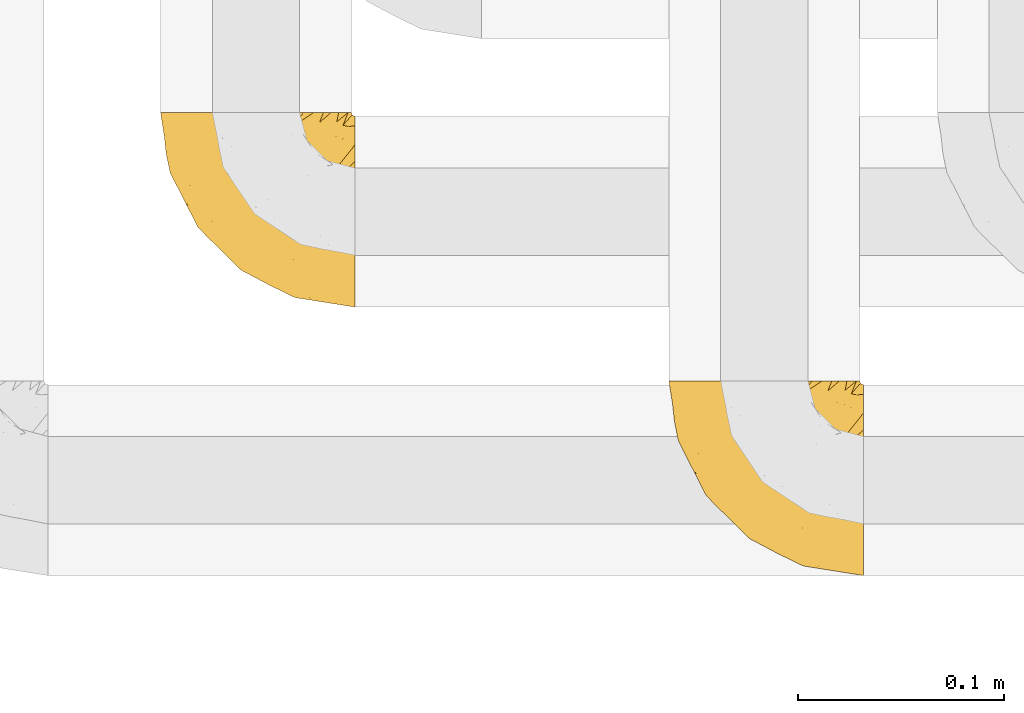
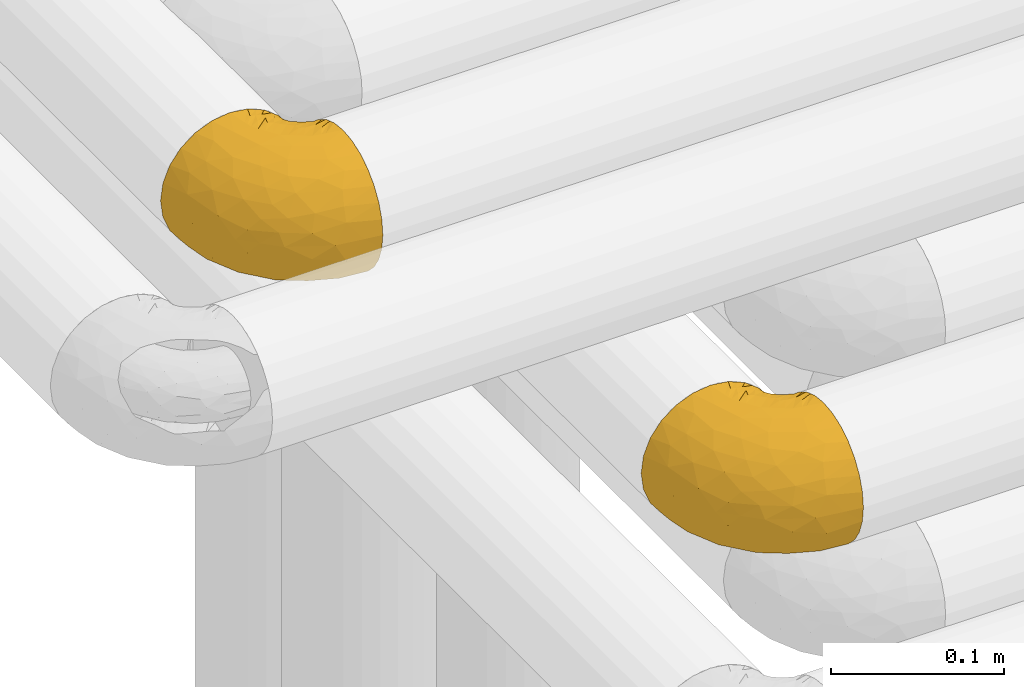
# One storey, part 143 of 827: 2 coverings.
"""IFC2X3 building model written with IfcOpenShell, lengths in millimetres."""

from ifc_helpers import new_model, entity, si_unit, converted_unit, derived_unit, direction, frame, origin, place, context, subcontext, project, spatial, faceted_brep, element, save


model = new_model("IFC2X3")

# Units and contexts
model_context = context("Model", 3, precision=0.01, world=origin(), true_north=direction((6.12303176911189e-17, 1.0)))
body_context = subcontext(model_context, "Body", "Model", "MODEL_VIEW")
ifc_project = project(units=[si_unit("LENGTHUNIT", "METRE", prefix="MILLI"), si_unit("AREAUNIT", "SQUARE_METRE"), si_unit("VOLUMEUNIT", "CUBIC_METRE"), converted_unit("PLANEANGLEUNIT", "DEGREE", entity("IfcRatioMeasure", 0.0174532925199433), si_unit("PLANEANGLEUNIT", "RADIAN"), dimensions=[0, 0, 0, 0, 0, 0, 0]), si_unit("MASSUNIT", "GRAM", prefix="KILO"), derived_unit("MASSDENSITYUNIT", [(si_unit("MASSUNIT", "GRAM", prefix="KILO"), 1), (si_unit("LENGTHUNIT", "METRE"), -3)]), derived_unit("MOMENTOFINERTIAUNIT", [(si_unit("LENGTHUNIT", "METRE"), 4)]), si_unit("TIMEUNIT", "SECOND"), si_unit("FREQUENCYUNIT", "HERTZ"), si_unit("THERMODYNAMICTEMPERATUREUNIT", "DEGREE_CELSIUS"), derived_unit("THERMALTRANSMITTANCEUNIT", [(si_unit("MASSUNIT", "GRAM", prefix="KILO"), 1), (si_unit("THERMODYNAMICTEMPERATUREUNIT", "KELVIN"), -1), (si_unit("TIMEUNIT", "SECOND"), -3)]), derived_unit("VOLUMETRICFLOWRATEUNIT", [(si_unit("LENGTHUNIT", "METRE"), 3), (si_unit("TIMEUNIT", "SECOND"), -1)]), derived_unit("MASSFLOWRATEUNIT", [(si_unit("MASSUNIT", "GRAM", prefix="KILO"), 1), (si_unit("TIMEUNIT", "SECOND"), -1)]), derived_unit("ROTATIONALFREQUENCYUNIT", [(si_unit("TIMEUNIT", "SECOND"), -1)]), si_unit("ELECTRICCURRENTUNIT", "AMPERE"), si_unit("ELECTRICVOLTAGEUNIT", "VOLT"), si_unit("POWERUNIT", "WATT"), si_unit("FORCEUNIT", "NEWTON", prefix="KILO"), si_unit("ILLUMINANCEUNIT", "LUX"), si_unit("LUMINOUSFLUXUNIT", "LUMEN"), si_unit("LUMINOUSINTENSITYUNIT", "CANDELA"), derived_unit("USERDEFINED", [(si_unit("MASSUNIT", "GRAM", prefix="KILO"), -1), (si_unit("LENGTHUNIT", "METRE"), -2), (si_unit("TIMEUNIT", "SECOND"), 3), (si_unit("LUMINOUSFLUXUNIT", "LUMEN"), 1)]), derived_unit("LINEARVELOCITYUNIT", [(si_unit("LENGTHUNIT", "METRE"), 1), (si_unit("TIMEUNIT", "SECOND"), -1)]), si_unit("PRESSUREUNIT", "PASCAL"), derived_unit("USERDEFINED", [(si_unit("LENGTHUNIT", "METRE"), -2), (si_unit("MASSUNIT", "GRAM", prefix="KILO"), 1), (si_unit("TIMEUNIT", "SECOND"), -2)]), derived_unit("LINEARFORCEUNIT", [(si_unit("MASSUNIT", "GRAM", prefix="KILO"), 1), (si_unit("LENGTHUNIT", "METRE"), 1), (si_unit("TIMEUNIT", "SECOND"), -2), (si_unit("LENGTHUNIT", "METRE"), -1)]), derived_unit("PLANARFORCEUNIT", [(si_unit("MASSUNIT", "GRAM", prefix="KILO"), 1), (si_unit("LENGTHUNIT", "METRE"), 1), (si_unit("TIMEUNIT", "SECOND"), -2), (si_unit("LENGTHUNIT", "METRE"), -2)])], contexts=[model_context])

# Site, building, storey
site_placement = place(None, origin())
site = spatial("IfcSite", under=ifc_project, at=site_placement, CompositionType="ELEMENT")
building_placement = place(site_placement, origin())
building = spatial("IfcBuilding", under=site, at=building_placement, CompositionType="ELEMENT")
storey_placement = place(building_placement, frame((0.0, 0.0, 28200.0)))
storey = spatial("IfcBuildingStorey", under=building, at=storey_placement, Name="08", CompositionType="ELEMENT", Elevation=28200.0)

# Coverings
covering_1_placement = place(storey_placement, frame((30622.54, 14182.21, 3352.2)))
element("IfcCovering", 1, at=covering_1_placement, inside=storey, Name=":ADSK_", ObjectType=":ADSK_", PredefinedType="INSULATION", context=body_context, shape_type="Brep", body=[
    faceted_brep([(95.8, 18.98, 83.91), (95.8, 11.67, 76.59), (95.8, 6.17, 67.83), (95.8, 2.75, 58.07), (95.8, 1.6, 47.8), (95.8, 2.75, 37.51), (95.8, 6.17, 27.74), (95.8, 11.68, 18.98), (95.8, 19.0, 11.67), (95.8, 27.76, 6.17), (95.8, 37.52, 2.75), (95.8, 47.8, 1.6), (95.8, 51.94, 2.06), (95.8, 55.01, 2.41), (95.8, 58.08, 2.75), (95.8, 62.96, 4.46), (95.8, 67.85, 6.17), (95.8, 72.23, 8.93), (95.8, 76.61, 11.68), (95.8, 80.26, 15.34), (95.8, 83.92, 19.0), (95.8, 89.42, 27.76), (95.8, 91.13, 32.64), (95.8, 92.84, 37.52), (95.8, 94.0, 47.8), (95.8, 92.84, 58.08), (95.8, 91.13, 62.96), (95.8, 89.42, 67.85), (95.8, 83.91, 76.61), (95.8, 80.25, 80.26), (95.8, 76.59, 83.92), (95.8, 72.21, 86.67), (95.8, 67.83, 89.42), (95.8, 62.95, 91.13), (95.8, 58.07, 92.84), (95.8, 55.0, 93.18), (95.8, 51.94, 93.53), (95.8, 47.8, 94.0), (95.8, 37.51, 92.84), (95.8, 27.74, 89.42), (94.0, 95.8, 47.8), (92.42, 95.8, 35.84), (87.81, 95.8, 24.7), (84.13, 95.8, 19.91), (80.46, 95.8, 15.13), (75.68, 95.8, 11.46), (70.9, 95.8, 7.78), (65.32, 95.8, 5.48), (59.75, 95.8, 3.17), (56.14, 95.8, 2.69), (54.06, 95.8, 2.42), (51.97, 95.8, 2.14), (47.8, 95.8, 1.6), (35.84, 95.8, 3.17), (24.7, 95.8, 7.78), (15.13, 95.8, 15.13), (7.78, 95.8, 24.7), (3.17, 95.8, 35.84), (1.6, 95.8, 47.8), (3.17, 95.8, 59.75), (7.78, 95.8, 70.9), (15.13, 95.8, 80.46), (24.7, 95.8, 87.81), (35.84, 95.8, 92.42), (47.8, 95.8, 94.0), (51.97, 95.8, 93.45), (56.14, 95.8, 92.9), (59.75, 95.8, 92.42), (65.32, 95.8, 90.11), (70.9, 95.8, 87.81), (75.68, 95.8, 84.13), (80.46, 95.8, 80.46), (84.13, 95.8, 75.68), (87.81, 95.8, 70.9), (92.42, 95.8, 59.75), (15.84, 60.58, 71.98), (6.99, 74.11, 63.6), (14.39, 51.59, 59.72), (6.21, 66.69, 47.8), (4.26, 76.19, 55.16), (3.39, 84.43, 47.8), (31.2, 31.2, 63.76), (26.47, 42.88, 72.22), (11.44, 79.41, 74.18), (47.66, 60.7, 92.52), (61.85, 61.85, 94.0), (59.25, 65.75, 94.0), (56.65, 69.64, 94.0), (54.05, 73.53, 94.0), (51.45, 77.43, 94.0), (19.8, 74.59, 82.14), (26.22, 54.72, 80.34), (31.58, 64.18, 87.52), (38.36, 37.94, 79.59), (51.54, 25.89, 78.25), (51.6, 34.73, 85.01), (55.97, 42.89, 90.25), (62.88, 49.83, 93.2), (41.35, 48.58, 87.23), (82.24, 22.41, 85.55), (40.88, 78.69, 93.0), (29.0, 81.64, 89.31), (74.06, 6.22, 61.31), (54.53, 12.11, 56.86), (57.98, 14.81, 68.34), (43.81, 21.61, 65.71), (38.22, 22.41, 56.99), (38.33, 30.12, 72.15), (74.76, 10.01, 70.34), (76.85, 15.36, 78.36), (84.43, 3.39, 47.8), (40.43, 19.59, 47.8), (30.01, 30.01, 47.8), (78.67, 41.19, 93.06), (92.06, 48.54, 94.0), (88.32, 49.28, 94.0), (85.6, 49.82, 94.0), (82.88, 50.37, 94.0), (80.15, 50.91, 94.0), (77.43, 51.45, 94.0), (76.36, 31.61, 89.88), (50.91, 80.15, 94.0), (50.37, 82.88, 94.0), (49.82, 85.6, 94.0), (49.28, 88.32, 94.0), (48.91, 90.19, 94.0), (48.54, 92.06, 94.0), (66.69, 6.21, 47.8), (73.53, 54.05, 94.0), (69.64, 56.65, 94.0), (65.75, 59.25, 94.0), (66.13, 24.66, 83.7), (19.59, 40.43, 47.8), (24.64, 35.17, 55.9), (53.56, 12.9, 47.8), (12.9, 53.56, 47.8), (82.81, 85.34, 81.75), (81.22, 78.44, 86.43), (86.57, 84.37, 79.8), (92.75, 89.05, 69.84), (89.68, 82.76, 79.5), (72.26, 86.31, 88.08), (64.73, 83.73, 91.6), (62.45, 77.31, 92.93), (60.63, 87.78, 92.43), (56.91, 87.91, 93.24), (58.14, 81.29, 93.36), (93.7, 93.97, 57.25), (83.4, 70.76, 89.41), (75.54, 63.67, 92.89), (79.46, 62.62, 92.66), (82.28, 90.64, 79.58), (76.25, 84.08, 86.51), (90.18, 77.45, 83.91), (87.92, 70.34, 88.76), (86.94, 91.35, 73.94), (65.12, 88.72, 90.94), (71.71, 71.28, 91.94), (75.21, 68.09, 91.98), (78.6, 91.07, 82.79), (87.27, 57.47, 93.16), (86.1, 62.99, 91.89), (94.52, 94.52, 47.8), (66.23, 76.47, 92.22), (84.69, 76.28, 86.29), (91.08, 69.96, 88.56), (71.77, 89.86, 87.72), (76.21, 78.94, 88.33), (68.59, 73.51, 92.18), (89.94, 89.62, 71.78), (76.22, 78.96, 7.27), (81.22, 78.46, 9.17), (71.7, 71.31, 3.66), (48.54, 92.06, 1.6), (50.37, 82.88, 1.6), (49.82, 85.6, 1.6), (49.28, 88.32, 1.6), (93.7, 93.97, 38.35), (89.95, 89.63, 23.84), (82.88, 50.37, 1.6), (85.6, 49.82, 1.6), (92.06, 48.54, 1.6), (88.32, 49.28, 1.6), (89.68, 82.77, 16.1), (87.92, 70.36, 6.84), (62.45, 77.31, 2.66), (66.24, 76.47, 3.37), (56.65, 69.64, 1.6), (59.25, 65.75, 1.6), (78.6, 91.06, 12.8), (60.63, 87.78, 3.16), (56.91, 87.91, 2.35), (92.76, 89.06, 25.77), (76.25, 84.09, 9.09), (82.28, 90.65, 16.02), (82.81, 85.35, 13.85), (54.05, 73.53, 1.6), (51.45, 77.43, 1.6), (58.14, 81.29, 2.23), (90.18, 77.46, 11.69), (84.7, 76.29, 9.31), (87.25, 57.47, 2.43), (75.58, 63.71, 2.71), (75.2, 68.11, 3.61), (83.39, 70.77, 6.18), (90.73, 69.52, 6.77), (79.47, 62.64, 2.93), (86.94, 91.35, 21.66), (65.75, 59.25, 1.6), (86.75, 84.6, 16.09), (86.08, 62.98, 3.7), (77.43, 51.45, 1.6), (73.53, 54.05, 1.6), (69.64, 56.65, 1.6), (64.73, 83.73, 3.99), (50.91, 80.15, 1.6), (65.12, 88.72, 4.65), (72.26, 86.3, 7.51), (61.85, 61.85, 1.6), (68.62, 73.56, 3.43), (74.03, 91.36, 9.46), (80.15, 50.91, 1.6), (49.81, 62.87, 2.4), (4.26, 76.19, 40.43), (19.95, 73.57, 13.57), (30.61, 56.07, 11.3), (25.71, 49.77, 18.65), (22.43, 44.73, 27.26), (15.85, 60.58, 23.61), (60.69, 47.64, 3.07), (40.49, 78.32, 2.69), (14.39, 51.59, 35.87), (6.99, 74.11, 31.99), (29.56, 76.04, 6.71), (11.45, 79.41, 21.41), (57.98, 14.82, 27.24), (74.06, 6.22, 34.26), (54.52, 12.12, 38.73), (43.47, 23.51, 26.97), (31.2, 31.2, 31.83), (33.27, 34.96, 23.4), (64.26, 33.86, 6.91), (74.29, 38.94, 3.4), (80.41, 30.23, 5.84), (41.67, 20.67, 35.73), (24.64, 35.17, 39.69), (73.62, 15.85, 17.6), (78.98, 22.59, 10.38), (53.69, 21.56, 20.6), (42.86, 55.94, 5.36), (79.66, 9.19, 24.84), (58.41, 25.79, 13.87), (47.11, 41.16, 9.06), (38.37, 37.95, 15.99)], [[[0, 1, 2, 3, 4, 5, 6, 7, 8, 9, 10, 11, 12, 13, 14, 15, 16, 17, 18, 19, 20, 21, 22, 23, 24, 25, 26, 27, 28, 29, 30, 31, 32, 33, 34, 35, 36, 37, 38, 39]], [[40, 41, 42, 43, 44, 45, 46, 47, 48, 49, 50, 51, 52, 53, 54, 55, 56, 57, 58, 59, 60, 61, 62, 63, 64, 65, 66, 67, 68, 69, 70, 71, 72, 73, 74]], [[75, 76, 77]], [[78, 79, 80]], [[77, 81, 82]], [[76, 75, 83]], [[84, 85, 86, 87, 88, 89]], [[90, 91, 92]], [[76, 60, 59]], [[93, 94, 95]], [[90, 62, 61]], [[83, 61, 60]], [[96, 97, 84]], [[98, 93, 95]], [[0, 39, 99]], [[100, 84, 89]], [[62, 101, 63]], [[2, 102, 3]], [[92, 84, 100]], [[103, 102, 104]], [[103, 105, 106]], [[93, 107, 94]], [[1, 108, 2]], [[92, 101, 90]], [[108, 1, 109]], [[102, 110, 3]], [[93, 82, 107]], [[102, 108, 104]], [[111, 106, 112]], [[109, 0, 99]], [[113, 37, 114, 115, 116, 117, 118, 119]], [[120, 38, 113]], [[100, 89, 121, 122, 123, 124, 125, 126, 64]], [[127, 102, 103]], [[97, 119, 128, 129, 130, 85]], [[99, 120, 131]], [[132, 133, 77]], [[59, 80, 79]], [[1, 0, 109]], [[98, 84, 92]], [[94, 109, 131]], [[120, 39, 38]], [[93, 91, 82]], [[104, 94, 105]], [[97, 113, 119]], [[95, 120, 96]], [[83, 90, 61]], [[91, 93, 98]], [[64, 63, 100]], [[100, 63, 101]], [[77, 76, 79]], [[133, 106, 81]], [[84, 97, 85]], [[113, 96, 120]], [[113, 97, 96]], [[37, 113, 38]], [[110, 102, 127]], [[110, 4, 3]], [[103, 111, 134, 127]], [[90, 75, 91]], [[82, 81, 107]], [[91, 75, 82]], [[77, 82, 75]], [[76, 83, 60]], [[90, 83, 75]], [[105, 107, 81]], [[94, 131, 95]], [[105, 94, 107]], [[109, 94, 104]], [[120, 95, 131]], [[98, 95, 96]], [[84, 98, 96]], [[98, 92, 91]], [[106, 105, 81]], [[103, 104, 105]], [[133, 132, 112]], [[103, 106, 111]], [[77, 78, 135, 132]], [[81, 77, 133]], [[106, 133, 112]], [[120, 99, 39]], [[109, 99, 131]], [[59, 58, 80]], [[59, 79, 76]], [[90, 101, 62]], [[100, 101, 92]], [[2, 108, 102]], [[109, 104, 108]], [[78, 77, 79]], [[136, 137, 138]], [[27, 139, 140]], [[141, 142, 143]], [[144, 145, 121]], [[146, 89, 88]], [[147, 139, 25]], [[148, 149, 150]], [[136, 151, 152]], [[147, 40, 74]], [[24, 147, 25]], [[153, 148, 154]], [[33, 116, 34]], [[73, 151, 155]], [[114, 37, 36, 35, 34, 116, 115]], [[146, 156, 144]], [[157, 85, 130]], [[158, 149, 148]], [[151, 159, 152]], [[117, 33, 160]], [[29, 153, 154]], [[155, 74, 73]], [[161, 128, 119]], [[65, 64, 126, 125, 124, 123, 122, 67, 66]], [[162, 147, 24]], [[27, 140, 28]], [[149, 129, 150]], [[139, 27, 26, 25]], [[68, 144, 69]], [[129, 128, 150]], [[163, 87, 86]], [[130, 129, 149]], [[122, 145, 67]], [[153, 164, 148]], [[161, 119, 160]], [[165, 30, 154]], [[150, 154, 148]], [[128, 161, 150]], [[30, 165, 31]], [[145, 144, 68]], [[89, 146, 144]], [[87, 163, 143]], [[166, 156, 142]], [[88, 87, 143]], [[161, 154, 150]], [[154, 30, 29]], [[29, 28, 153]], [[28, 140, 153]], [[164, 153, 140]], [[140, 137, 164]], [[158, 148, 164]], [[157, 130, 158]], [[164, 137, 158]], [[158, 137, 157]], [[167, 137, 136]], [[168, 85, 157]], [[152, 168, 167]], [[167, 168, 157]], [[163, 152, 141]], [[151, 73, 72]], [[159, 72, 71]], [[88, 142, 146]], [[144, 156, 69]], [[146, 142, 156]], [[70, 166, 71]], [[142, 141, 166]], [[70, 69, 156]], [[141, 159, 71]], [[167, 136, 152]], [[138, 137, 140]], [[155, 136, 169]], [[136, 155, 151]], [[74, 155, 169]], [[152, 159, 141]], [[151, 72, 159]], [[168, 152, 163]], [[137, 167, 157]], [[163, 86, 168]], [[85, 168, 86]], [[116, 33, 117]], [[130, 149, 158]], [[67, 145, 68]], [[121, 89, 144]], [[145, 122, 121]], [[40, 147, 162]], [[169, 147, 74]], [[160, 33, 32]], [[161, 160, 32]], [[160, 119, 118, 117]], [[139, 147, 169]], [[139, 169, 138]], [[161, 32, 31]], [[141, 143, 163]], [[88, 143, 142]], [[71, 166, 141]], [[156, 166, 70]], [[139, 138, 140]], [[169, 136, 138]], [[154, 161, 165]], [[161, 31, 165]], [[170, 171, 172]], [[173, 52, 51, 50, 49, 48, 174, 175, 176]], [[177, 178, 41]], [[179, 15, 180]], [[12, 11, 181, 182, 180, 14, 13]], [[183, 21, 20]], [[19, 18, 184]], [[185, 186, 187]], [[186, 188, 187]], [[43, 189, 44]], [[190, 191, 47]], [[23, 22, 21, 192]], [[193, 194, 195]], [[40, 162, 177]], [[196, 197, 198]], [[24, 23, 177]], [[199, 200, 183]], [[201, 15, 179]], [[47, 46, 190]], [[202, 203, 204]], [[203, 172, 171]], [[205, 206, 184]], [[207, 41, 178]], [[16, 15, 201]], [[14, 180, 15]], [[204, 203, 200]], [[208, 203, 202]], [[162, 24, 177]], [[48, 47, 191]], [[198, 197, 190]], [[199, 184, 204]], [[171, 195, 209]], [[210, 211, 212]], [[206, 212, 213]], [[205, 17, 210]], [[184, 206, 204]], [[210, 212, 206]], [[185, 196, 214]], [[190, 215, 191]], [[216, 45, 214]], [[186, 217, 193]], [[190, 216, 198]], [[199, 20, 19]], [[196, 185, 187]], [[199, 183, 20]], [[184, 199, 19]], [[199, 204, 200]], [[206, 202, 204]], [[171, 183, 200]], [[203, 208, 172]], [[172, 208, 218]], [[171, 200, 203]], [[218, 188, 219]], [[195, 170, 193]], [[217, 186, 185]], [[193, 219, 186]], [[193, 170, 219]], [[207, 194, 42]], [[217, 220, 189]], [[216, 190, 46]], [[214, 196, 198]], [[44, 220, 45]], [[214, 198, 216]], [[216, 46, 45]], [[214, 45, 220]], [[42, 194, 43]], [[189, 193, 217]], [[207, 195, 194]], [[209, 195, 178]], [[41, 207, 42]], [[195, 207, 178]], [[43, 194, 189]], [[193, 189, 194]], [[171, 170, 195]], [[170, 172, 219]], [[218, 219, 172]], [[188, 186, 219]], [[206, 213, 202]], [[208, 202, 213]], [[201, 210, 16]], [[215, 190, 197]], [[215, 174, 191]], [[174, 48, 191]], [[201, 179, 221, 211]], [[210, 201, 211]], [[23, 192, 177]], [[40, 177, 41]], [[178, 177, 192]], [[21, 183, 192]], [[209, 192, 183]], [[205, 18, 17]], [[17, 16, 210]], [[217, 185, 214]], [[189, 220, 44]], [[214, 220, 217]], [[192, 209, 178]], [[171, 209, 183]], [[206, 205, 210]], [[18, 205, 184]], [[222, 197, 196, 187, 188, 218]], [[57, 223, 80]], [[224, 225, 226]], [[226, 227, 228]], [[229, 218, 208, 213, 212, 211]], [[230, 52, 173, 176, 175, 174, 215, 197]], [[231, 232, 228]], [[231, 78, 223]], [[223, 57, 232]], [[224, 233, 225]], [[233, 54, 53]], [[234, 232, 56]], [[56, 55, 234]], [[234, 224, 228]], [[235, 236, 237]], [[224, 55, 54]], [[238, 239, 240]], [[52, 230, 53]], [[241, 242, 243]], [[239, 244, 245]], [[11, 10, 242]], [[236, 6, 5]], [[7, 246, 8]], [[8, 247, 9]], [[238, 248, 235]], [[222, 229, 249]], [[242, 211, 221, 179, 180, 182, 181, 11]], [[233, 53, 230]], [[111, 112, 244]], [[250, 6, 236]], [[247, 251, 241]], [[6, 250, 7]], [[127, 236, 110]], [[249, 229, 252]], [[247, 8, 246]], [[235, 246, 250]], [[236, 5, 110]], [[235, 244, 238]], [[237, 236, 127]], [[243, 9, 247]], [[252, 229, 241]], [[56, 232, 57]], [[222, 230, 197]], [[225, 249, 252]], [[249, 233, 230]], [[54, 233, 224]], [[231, 228, 227]], [[245, 132, 231]], [[249, 225, 233]], [[226, 225, 253]], [[235, 250, 236]], [[246, 7, 250]], [[251, 247, 246]], [[243, 247, 241]], [[248, 246, 235]], [[252, 251, 253]], [[229, 222, 218]], [[230, 222, 249]], [[5, 4, 110]], [[237, 127, 134, 111]], [[238, 244, 239]], [[224, 234, 55]], [[232, 234, 228]], [[242, 241, 229]], [[10, 9, 243]], [[211, 242, 229]], [[10, 243, 242]], [[80, 223, 78]], [[80, 58, 57]], [[231, 223, 232]], [[227, 240, 239]], [[224, 226, 228]], [[240, 226, 253]], [[227, 239, 245]], [[226, 240, 227]], [[251, 248, 253]], [[240, 253, 248]], [[244, 235, 237]], [[237, 111, 244]], [[132, 245, 112]], [[112, 245, 244]], [[135, 78, 231, 132]], [[227, 245, 231]], [[248, 238, 240]], [[246, 248, 251]], [[251, 252, 241]], [[225, 252, 253]]]),
])
covering_2_placement = place(storey_placement, frame((30868.73, 14052.21, 3152.2)))
element("IfcCovering", 2, at=covering_2_placement, inside=storey, Name=":ADSK_", ObjectType=":ADSK_", PredefinedType="INSULATION", context=body_context, shape_type="Brep", body=[
    faceted_brep([(95.8, 37.51, 92.84), (95.8, 27.74, 89.42), (95.8, 18.98, 83.91), (95.8, 11.67, 76.59), (95.8, 6.17, 67.83), (95.8, 2.75, 58.07), (95.8, 1.6, 47.8), (95.8, 2.75, 37.51), (95.8, 6.17, 27.74), (95.8, 11.68, 18.98), (95.8, 19.0, 11.67), (95.8, 27.76, 6.17), (95.8, 37.52, 2.75), (95.8, 47.8, 1.6), (95.8, 51.94, 2.06), (95.8, 55.01, 2.41), (95.8, 58.08, 2.75), (95.8, 62.96, 4.46), (95.8, 67.85, 6.17), (95.8, 72.23, 8.93), (95.8, 76.61, 11.68), (95.8, 80.26, 15.34), (95.8, 83.92, 19.0), (95.8, 89.42, 27.76), (95.8, 91.13, 32.64), (95.8, 92.84, 37.52), (95.8, 94.0, 47.8), (95.8, 92.84, 58.08), (95.8, 91.13, 62.96), (95.8, 89.42, 67.85), (95.8, 83.91, 76.61), (95.8, 80.25, 80.26), (95.8, 76.59, 83.92), (95.8, 72.21, 86.67), (95.8, 67.83, 89.42), (95.8, 62.95, 91.13), (95.8, 58.07, 92.84), (95.8, 55.0, 93.18), (95.8, 51.94, 93.53), (95.8, 47.8, 94.0), (94.0, 95.8, 47.8), (92.42, 95.8, 35.84), (87.81, 95.8, 24.7), (84.13, 95.8, 19.91), (80.46, 95.8, 15.13), (75.68, 95.8, 11.46), (70.9, 95.8, 7.78), (65.32, 95.8, 5.48), (59.75, 95.8, 3.17), (56.14, 95.8, 2.69), (54.06, 95.8, 2.42), (51.97, 95.8, 2.14), (47.8, 95.8, 1.6), (35.84, 95.8, 3.17), (24.7, 95.8, 7.78), (15.13, 95.8, 15.13), (7.78, 95.8, 24.7), (3.17, 95.8, 35.84), (1.6, 95.8, 47.8), (3.17, 95.8, 59.75), (7.78, 95.8, 70.9), (15.13, 95.8, 80.46), (24.7, 95.8, 87.81), (35.84, 95.8, 92.42), (47.8, 95.8, 94.0), (51.97, 95.8, 93.45), (56.14, 95.8, 92.9), (59.75, 95.8, 92.42), (65.32, 95.8, 90.11), (70.9, 95.8, 87.81), (75.68, 95.8, 84.13), (80.46, 95.8, 80.46), (84.13, 95.8, 75.68), (87.81, 95.8, 70.9), (92.42, 95.8, 59.75), (15.84, 60.58, 71.98), (6.99, 74.11, 63.6), (14.39, 51.59, 59.72), (6.21, 66.69, 47.8), (4.26, 76.19, 55.16), (3.39, 84.43, 47.8), (31.2, 31.2, 63.76), (26.47, 42.88, 72.22), (11.44, 79.41, 74.18), (47.66, 60.7, 92.52), (61.85, 61.85, 94.0), (59.25, 65.75, 94.0), (56.65, 69.64, 94.0), (54.05, 73.53, 94.0), (51.45, 77.43, 94.0), (19.8, 74.59, 82.14), (26.22, 54.72, 80.34), (31.58, 64.18, 87.52), (38.36, 37.94, 79.59), (51.54, 25.89, 78.25), (51.6, 34.73, 85.01), (55.97, 42.89, 90.25), (62.88, 49.83, 93.2), (41.35, 48.58, 87.23), (82.24, 22.41, 85.55), (40.88, 78.69, 93.0), (29.0, 81.64, 89.31), (74.06, 6.22, 61.31), (54.53, 12.11, 56.86), (57.98, 14.81, 68.34), (43.81, 21.61, 65.71), (38.22, 22.41, 56.99), (38.33, 30.12, 72.15), (74.76, 10.01, 70.34), (76.85, 15.36, 78.36), (84.43, 3.39, 47.8), (40.43, 19.59, 47.8), (30.01, 30.01, 47.8), (78.67, 41.19, 93.06), (92.06, 48.54, 94.0), (88.32, 49.28, 94.0), (85.6, 49.82, 94.0), (82.88, 50.37, 94.0), (80.15, 50.91, 94.0), (77.43, 51.45, 94.0), (76.36, 31.61, 89.88), (50.91, 80.15, 94.0), (50.37, 82.88, 94.0), (49.82, 85.6, 94.0), (49.28, 88.32, 94.0), (48.91, 90.19, 94.0), (48.54, 92.06, 94.0), (66.69, 6.21, 47.8), (73.53, 54.05, 94.0), (69.64, 56.65, 94.0), (65.75, 59.25, 94.0), (66.13, 24.66, 83.7), (19.59, 40.43, 47.8), (24.64, 35.17, 55.9), (53.56, 12.9, 47.8), (12.9, 53.56, 47.8), (82.81, 85.34, 81.75), (81.22, 78.44, 86.43), (86.57, 84.37, 79.8), (92.75, 89.05, 69.84), (72.26, 86.31, 88.08), (64.73, 83.73, 91.6), (62.45, 77.31, 92.93), (60.63, 87.78, 92.43), (56.91, 87.91, 93.24), (58.14, 81.29, 93.36), (93.7, 93.97, 57.25), (83.4, 70.76, 89.41), (75.54, 63.67, 92.89), (79.46, 62.62, 92.66), (82.28, 90.64, 79.58), (76.25, 84.08, 86.51), (90.18, 77.45, 83.91), (87.92, 70.34, 88.76), (65.12, 88.72, 90.94), (71.71, 71.28, 91.94), (75.21, 68.09, 91.98), (78.6, 91.07, 82.79), (87.27, 57.47, 93.16), (86.94, 91.35, 73.94), (86.1, 62.99, 91.89), (94.52, 94.52, 47.8), (89.68, 82.76, 79.5), (66.23, 76.47, 92.22), (84.69, 76.28, 86.29), (91.08, 69.96, 88.56), (71.77, 89.86, 87.72), (76.21, 78.94, 88.33), (68.59, 73.51, 92.18), (89.94, 89.62, 71.78), (76.25, 84.09, 9.09), (72.26, 86.3, 7.51), (78.6, 91.06, 12.8), (49.28, 88.32, 1.6), (48.54, 92.06, 1.6), (50.37, 82.88, 1.6), (49.82, 85.6, 1.6), (93.7, 93.97, 38.35), (89.95, 89.63, 23.84), (82.88, 50.37, 1.6), (85.6, 49.82, 1.6), (92.06, 48.54, 1.6), (88.32, 49.28, 1.6), (89.68, 82.77, 16.1), (87.92, 70.36, 6.84), (62.45, 77.31, 2.66), (66.24, 76.47, 3.37), (56.65, 69.64, 1.6), (59.25, 65.75, 1.6), (60.63, 87.78, 3.16), (56.91, 87.91, 2.35), (92.76, 89.06, 25.77), (82.28, 90.65, 16.02), (82.81, 85.35, 13.85), (54.05, 73.53, 1.6), (51.45, 77.43, 1.6), (58.14, 81.29, 2.23), (90.18, 77.46, 11.69), (84.7, 76.29, 9.31), (87.25, 57.47, 2.43), (75.58, 63.71, 2.71), (75.2, 68.11, 3.61), (83.39, 70.77, 6.18), (71.7, 71.31, 3.66), (81.22, 78.46, 9.17), (90.73, 69.52, 6.77), (79.47, 62.64, 2.93), (86.94, 91.35, 21.66), (65.75, 59.25, 1.6), (86.75, 84.6, 16.09), (86.08, 62.98, 3.7), (77.43, 51.45, 1.6), (73.53, 54.05, 1.6), (69.64, 56.65, 1.6), (64.73, 83.73, 3.99), (50.91, 80.15, 1.6), (65.12, 88.72, 4.65), (61.85, 61.85, 1.6), (68.62, 73.56, 3.43), (76.22, 78.96, 7.27), (74.03, 91.36, 9.46), (80.15, 50.91, 1.6), (49.81, 62.87, 2.4), (4.26, 76.19, 40.43), (19.95, 73.57, 13.57), (30.61, 56.07, 11.3), (25.71, 49.77, 18.65), (22.43, 44.73, 27.26), (15.85, 60.58, 23.61), (60.69, 47.64, 3.07), (40.49, 78.32, 2.69), (14.39, 51.59, 35.87), (6.99, 74.11, 31.99), (29.56, 76.04, 6.71), (11.45, 79.41, 21.41), (57.98, 14.82, 27.24), (74.06, 6.22, 34.26), (54.52, 12.12, 38.73), (43.47, 23.51, 26.97), (31.2, 31.2, 31.83), (33.27, 34.96, 23.4), (64.26, 33.86, 6.91), (74.29, 38.94, 3.4), (80.41, 30.23, 5.84), (24.64, 35.17, 39.69), (73.62, 15.85, 17.6), (78.98, 22.59, 10.38), (53.69, 21.56, 20.6), (42.86, 55.94, 5.36), (41.67, 20.67, 35.73), (79.66, 9.19, 24.84), (58.41, 25.79, 13.87), (47.11, 41.16, 9.06), (38.37, 37.95, 15.99)], [[[0, 1, 2, 3, 4, 5, 6, 7, 8, 9, 10, 11, 12, 13, 14, 15, 16, 17, 18, 19, 20, 21, 22, 23, 24, 25, 26, 27, 28, 29, 30, 31, 32, 33, 34, 35, 36, 37, 38, 39]], [[40, 41, 42, 43, 44, 45, 46, 47, 48, 49, 50, 51, 52, 53, 54, 55, 56, 57, 58, 59, 60, 61, 62, 63, 64, 65, 66, 67, 68, 69, 70, 71, 72, 73, 74]], [[75, 76, 77]], [[78, 79, 80]], [[77, 81, 82]], [[76, 75, 83]], [[84, 85, 86, 87, 88, 89]], [[90, 91, 92]], [[76, 60, 59]], [[93, 94, 95]], [[90, 62, 61]], [[83, 61, 60]], [[96, 97, 84]], [[98, 93, 95]], [[2, 1, 99]], [[100, 84, 89]], [[62, 101, 63]], [[4, 102, 5]], [[92, 84, 100]], [[103, 102, 104]], [[103, 105, 106]], [[93, 107, 94]], [[3, 108, 4]], [[92, 101, 90]], [[108, 3, 109]], [[102, 110, 5]], [[93, 82, 107]], [[102, 108, 104]], [[111, 106, 112]], [[109, 2, 99]], [[113, 39, 114, 115, 116, 117, 118, 119]], [[120, 0, 113]], [[100, 89, 121, 122, 123, 124, 125, 126, 64]], [[127, 102, 103]], [[97, 119, 128, 129, 130, 85]], [[99, 120, 131]], [[132, 133, 77]], [[59, 80, 79]], [[3, 2, 109]], [[98, 84, 92]], [[94, 109, 131]], [[120, 1, 0]], [[93, 91, 82]], [[104, 94, 105]], [[97, 113, 119]], [[95, 120, 96]], [[83, 90, 61]], [[91, 93, 98]], [[64, 63, 100]], [[100, 63, 101]], [[77, 76, 79]], [[133, 106, 81]], [[84, 97, 85]], [[113, 96, 120]], [[113, 97, 96]], [[39, 113, 0]], [[110, 102, 127]], [[110, 6, 5]], [[103, 111, 134, 127]], [[90, 75, 91]], [[82, 81, 107]], [[91, 75, 82]], [[77, 82, 75]], [[76, 83, 60]], [[90, 83, 75]], [[105, 107, 81]], [[94, 131, 95]], [[105, 94, 107]], [[109, 94, 104]], [[120, 95, 131]], [[98, 95, 96]], [[84, 98, 96]], [[98, 92, 91]], [[106, 105, 81]], [[103, 104, 105]], [[112, 106, 133]], [[103, 106, 111]], [[112, 133, 132]], [[81, 77, 133]], [[77, 78, 135, 132]], [[120, 99, 1]], [[109, 99, 131]], [[59, 58, 80]], [[59, 79, 76]], [[90, 101, 62]], [[100, 101, 92]], [[4, 108, 102]], [[109, 104, 108]], [[78, 77, 79]], [[136, 137, 138]], [[29, 28, 27, 139]], [[140, 141, 142]], [[143, 144, 121]], [[145, 89, 88]], [[146, 139, 27]], [[147, 148, 149]], [[136, 150, 151]], [[146, 40, 74]], [[26, 146, 27]], [[152, 147, 153]], [[35, 116, 36]], [[73, 72, 150]], [[114, 39, 38, 37, 36, 116, 115]], [[145, 154, 143]], [[155, 85, 130]], [[156, 148, 147]], [[150, 157, 151]], [[117, 35, 158]], [[31, 152, 153]], [[159, 74, 73]], [[160, 128, 119]], [[66, 65, 64, 126, 125, 124, 123, 122, 67]], [[161, 146, 26]], [[29, 162, 30]], [[148, 129, 149]], [[68, 143, 69]], [[129, 128, 149]], [[163, 87, 86]], [[130, 129, 148]], [[122, 144, 67]], [[152, 164, 147]], [[160, 119, 158]], [[165, 32, 153]], [[149, 153, 147]], [[128, 160, 149]], [[32, 165, 33]], [[144, 143, 68]], [[89, 145, 143]], [[87, 163, 142]], [[166, 154, 141]], [[88, 87, 142]], [[160, 153, 149]], [[153, 32, 31]], [[31, 30, 152]], [[30, 162, 152]], [[164, 152, 162]], [[162, 137, 164]], [[156, 147, 164]], [[155, 130, 156]], [[164, 137, 156]], [[156, 137, 155]], [[167, 137, 136]], [[168, 85, 155]], [[151, 168, 167]], [[167, 168, 155]], [[163, 151, 140]], [[71, 157, 72]], [[151, 167, 136]], [[88, 141, 145]], [[143, 154, 69]], [[145, 141, 154]], [[70, 166, 71]], [[141, 140, 166]], [[70, 69, 154]], [[140, 157, 71]], [[159, 73, 150]], [[138, 137, 162]], [[159, 136, 169]], [[136, 159, 150]], [[74, 159, 169]], [[151, 157, 140]], [[150, 72, 157]], [[168, 151, 163]], [[137, 167, 155]], [[163, 86, 168]], [[85, 168, 86]], [[116, 35, 117]], [[130, 148, 156]], [[67, 144, 68]], [[121, 89, 143]], [[144, 122, 121]], [[40, 146, 161]], [[169, 146, 74]], [[158, 35, 34]], [[160, 158, 34]], [[158, 119, 118, 117]], [[139, 146, 169]], [[138, 139, 169]], [[162, 29, 139]], [[160, 34, 33]], [[140, 142, 163]], [[88, 142, 141]], [[71, 166, 140]], [[154, 166, 70]], [[139, 138, 162]], [[169, 136, 138]], [[153, 160, 165]], [[160, 33, 165]], [[170, 171, 172]], [[173, 174, 52, 51, 50, 49, 48, 175, 176]], [[177, 178, 41]], [[179, 17, 180]], [[14, 13, 181, 182, 180, 16, 15]], [[183, 23, 22]], [[21, 20, 184]], [[185, 186, 187]], [[186, 188, 187]], [[43, 172, 44]], [[189, 190, 47]], [[25, 24, 23, 191]], [[170, 192, 193]], [[40, 161, 177]], [[194, 195, 196]], [[26, 25, 177]], [[197, 198, 183]], [[199, 17, 179]], [[47, 46, 189]], [[200, 201, 202]], [[201, 203, 204]], [[205, 206, 184]], [[207, 41, 178]], [[18, 17, 199]], [[16, 180, 17]], [[202, 201, 198]], [[208, 201, 200]], [[161, 26, 177]], [[48, 47, 190]], [[196, 195, 189]], [[197, 184, 202]], [[204, 193, 209]], [[210, 211, 212]], [[206, 212, 213]], [[205, 19, 210]], [[184, 206, 202]], [[210, 212, 206]], [[185, 194, 214]], [[189, 215, 190]], [[216, 45, 214]], [[186, 171, 170]], [[189, 216, 196]], [[197, 22, 21]], [[194, 185, 187]], [[197, 183, 22]], [[184, 197, 21]], [[197, 202, 198]], [[206, 200, 202]], [[204, 183, 198]], [[201, 208, 203]], [[203, 208, 217]], [[204, 198, 201]], [[217, 188, 218]], [[193, 219, 170]], [[171, 186, 185]], [[170, 218, 186]], [[170, 219, 218]], [[42, 207, 192]], [[171, 220, 172]], [[216, 189, 46]], [[214, 194, 196]], [[44, 220, 45]], [[214, 196, 216]], [[216, 46, 45]], [[214, 45, 220]], [[192, 43, 42]], [[204, 203, 219]], [[207, 193, 192]], [[209, 193, 178]], [[41, 207, 42]], [[193, 207, 178]], [[43, 192, 172]], [[170, 172, 192]], [[204, 219, 193]], [[219, 203, 218]], [[217, 218, 203]], [[188, 186, 218]], [[206, 213, 200]], [[208, 200, 213]], [[199, 210, 18]], [[215, 189, 195]], [[215, 175, 190]], [[175, 48, 190]], [[199, 179, 221, 211]], [[210, 199, 211]], [[25, 191, 177]], [[40, 177, 41]], [[178, 177, 191]], [[23, 183, 191]], [[209, 191, 183]], [[205, 20, 19]], [[19, 18, 210]], [[171, 185, 214]], [[172, 220, 44]], [[214, 220, 171]], [[191, 209, 178]], [[204, 209, 183]], [[206, 205, 210]], [[20, 205, 184]], [[222, 195, 194, 187, 188, 217]], [[57, 223, 80]], [[224, 225, 226]], [[226, 227, 228]], [[229, 217, 208, 213, 212, 211]], [[230, 52, 174, 173, 176, 175, 215, 195]], [[231, 232, 228]], [[231, 78, 223]], [[223, 57, 232]], [[224, 233, 225]], [[233, 54, 53]], [[234, 232, 56]], [[56, 55, 234]], [[234, 224, 228]], [[235, 236, 237]], [[224, 55, 54]], [[238, 239, 240]], [[52, 230, 53]], [[241, 242, 243]], [[227, 244, 231]], [[13, 12, 242]], [[236, 8, 7]], [[9, 245, 10]], [[10, 246, 11]], [[238, 247, 235]], [[222, 229, 248]], [[242, 211, 221, 179, 180, 182, 181, 13]], [[233, 53, 230]], [[111, 112, 249]], [[250, 8, 236]], [[246, 251, 241]], [[8, 250, 9]], [[127, 236, 110]], [[248, 229, 252]], [[246, 10, 245]], [[235, 245, 250]], [[236, 7, 110]], [[235, 249, 238]], [[237, 236, 127]], [[243, 11, 246]], [[252, 229, 241]], [[56, 232, 57]], [[222, 230, 195]], [[225, 248, 252]], [[248, 233, 230]], [[54, 233, 224]], [[231, 228, 227]], [[244, 132, 231]], [[248, 225, 233]], [[226, 225, 253]], [[235, 250, 236]], [[245, 9, 250]], [[251, 246, 245]], [[243, 246, 241]], [[247, 245, 235]], [[252, 251, 253]], [[229, 222, 217]], [[230, 222, 248]], [[7, 6, 110]], [[237, 127, 134, 111]], [[238, 249, 239]], [[224, 234, 55]], [[232, 234, 228]], [[242, 241, 229]], [[12, 11, 243]], [[211, 242, 229]], [[12, 243, 242]], [[80, 223, 78]], [[80, 58, 57]], [[231, 223, 232]], [[227, 240, 239]], [[224, 226, 228]], [[240, 226, 253]], [[227, 239, 244]], [[226, 240, 227]], [[251, 247, 253]], [[240, 253, 247]], [[249, 235, 237]], [[237, 111, 249]], [[112, 132, 244]], [[112, 244, 249]], [[78, 231, 132, 135]], [[249, 244, 239]], [[247, 238, 240]], [[245, 247, 251]], [[251, 252, 241]], [[225, 252, 253]]]),
])

save(model, "model.ifc")
